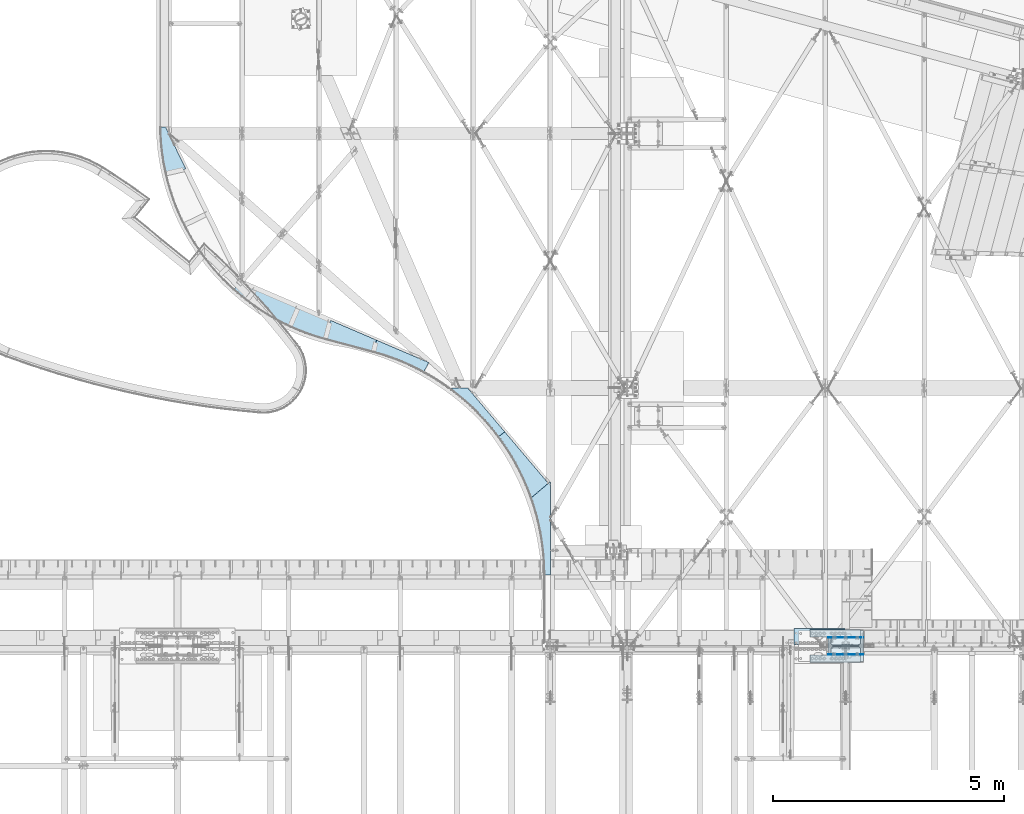
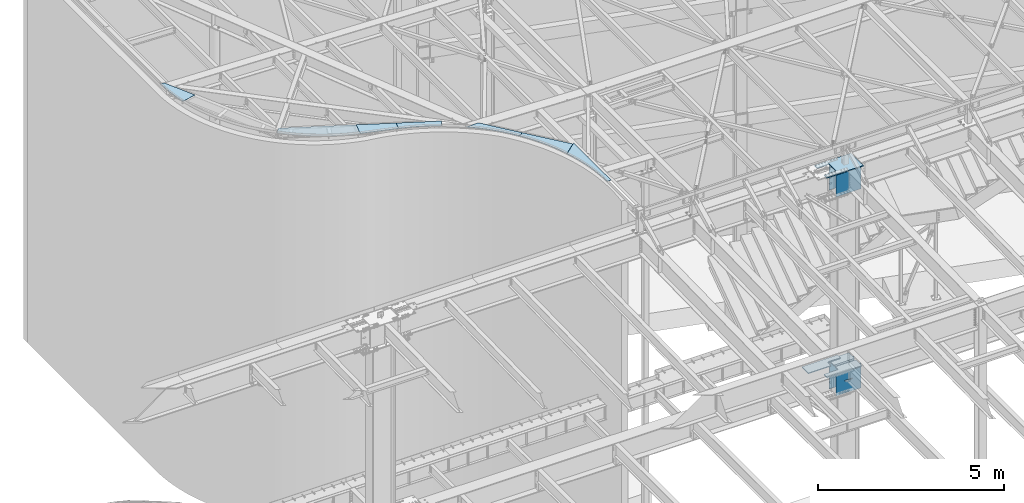
# One storey, part 1424 of 1763: 15 plates, 6 elements without a shape of their own.
"""IFC2X3 building model written with IfcOpenShell, lengths in millimetres."""

from ifc_helpers import new_model, si_unit, frame, origin_with_axes, place, context, subcontext, project, spatial, faceted_brep, material, type_object, element, aggregate, save


model = new_model("IFC2X3")

# Units and contexts
model_context = context("Model", 3, precision=1e-05, world=origin_with_axes())
body_context = subcontext(model_context, "Body", "Model", "MODEL_VIEW")
ifc_project = project(units=[si_unit("LENGTHUNIT", "METRE", prefix="MILLI"), si_unit("AREAUNIT", "SQUARE_METRE"), si_unit("VOLUMEUNIT", "CUBIC_METRE"), si_unit("MASSUNIT", "GRAM", prefix="KILO"), si_unit("TIMEUNIT", "SECOND"), si_unit("PLANEANGLEUNIT", "RADIAN"), si_unit("SOLIDANGLEUNIT", "STERADIAN"), si_unit("THERMODYNAMICTEMPERATUREUNIT", "DEGREE_CELSIUS"), si_unit("LUMINOUSINTENSITYUNIT", "LUMEN")], contexts=[model_context])

# Site, building, storey
site_placement = place(None, origin_with_axes())
site = spatial("IfcSite", under=ifc_project, at=site_placement, CompositionType="ELEMENT")
building_placement = place(site_placement, origin_with_axes())
building = spatial("IfcBuilding", under=site, at=building_placement, Name="Undefined", CompositionType="ELEMENT")
storey_placement = place(building_placement, origin_with_axes())
storey = spatial("IfcBuildingStorey", under=building, at=storey_placement, Name="Undefined", CompositionType="ELEMENT", Elevation=0.0)

# Assembly, plate
assembly_1_placement = place(storey_placement, origin_with_axes())
assembly_1 = element("IfcElementAssembly", 1, at=assembly_1_placement, inside=storey, Name="BEAM", AssemblyPlace="NOTDEFINED", PredefinedType="RIGID_FRAME")
ifc_material_1 = material(Name="STEEL/A36")
plate_type_1 = type_object("IfcPlateType", PredefinedType="NOTDEFINED")
plate_1_placement = place(assembly_1_placement, frame((-49648.670087662, 62339.0395447258, 12733.9691789539), z_axis=(-0.223550298253308, 0.974646099846385, 0.00949969499972398), x_axis=(0.974683206072181, 0.223579893016565, -0.00216315500016218)))
plate_1 = element("IfcPlate", 2, at=plate_1_placement, type_object=plate_type_1, material=ifc_material_1, Name="PLATE", context=body_context, shape_type="Brep", body=[
    faceted_brep([(1.33448866537947, -3.17499999995744, 104.323684619914), (1.34822535161948, 3.17500000004111, 104.263358693439), (0.937106392200803, 3.17499999999563, 1.45519152283669e-11), (0.92313183589431, -3.17500000000291, 0.0), (9.89252849467448, -3.17499999986649, 297.738603713762), (9.90626518091449, 3.17500000013206, 297.678277787301), (26.2313351696866, -3.17499999977372, 490.651890645284), (26.2450718559267, 3.17500000022665, 490.591564718823), (50.3244070862347, -3.17499999967367, 682.750639357633), (50.3381437724747, 3.17500000032669, 682.690313431158), (82.1326651935597, -3.17499999956999, 873.723264977889), (82.1464018797924, 3.17500000042855, 873.662939051414), (109.603907540455, -3.17499999949905, 1005.63523965912), (109.629004539267, 3.17500000050313, 1005.62946391445), (213.412231446287, -3.17499999944448, 981.745117184619), (439.812011718124, -3.17499999973006, -1.45519152283669e-11), (439.812011718132, 3.17500000026848, 1.45519152283669e-11), (213.412231446295, 3.1750000005577, 981.745117184633)], [[[0, 1, 2, 3]], [[4, 5, 1, 0]], [[6, 7, 5, 4]], [[8, 9, 7, 6]], [[10, 11, 9, 8]], [[12, 13, 11, 10]], [[14, 15, 16, 17]], [[8, 6, 4, 0, 3, 15, 14, 12, 10]], [[16, 15, 3, 2]], [[17, 16, 2, 1, 5, 7, 9, 11, 13]], [[14, 17, 13, 12]]]),
])
aggregate(assembly_1, [plate_1])

# Assembly, plates
assembly_2_placement = place(storey_placement, origin_with_axes())
assembly_2 = element("IfcElementAssembly", 3, at=assembly_2_placement, inside=storey, Name="BEAM", AssemblyPlace="NOTDEFINED", PredefinedType="RIGID_FRAME")
plate_type_2 = type_object("IfcPlateType", PredefinedType="NOTDEFINED")
plate_2_placement = place(assembly_2_placement, frame((-46201.9714651139, 58759.1172312443, 12641.5934711025), z_axis=(-0.965590600405951, 0.258452114647502, 0.0289360820068796), x_axis=(0.258673208951071, 0.965956134817291, 0.00411297699922236)))
plate_2 = element("IfcPlate", 4, at=plate_2_placement, type_object=plate_type_2, material=ifc_material_1, Name="PLATE", context=body_context, shape_type="Brep", body=[
    faceted_brep([(0.436761683944496, -3.17499999992651, 99.9227465770309), (0.410633117928228, 3.17500000007567, 99.7389239276454), (0.383936294565501, 3.17500000000291, 1.45519152283669e-11), (0.410015657325857, -3.17500000000109, -7.27595761418343e-12), (8.28393571890774, -3.17499999978463, 293.44122971109), (8.25780715289875, 3.17500000021755, 293.257407061719), (23.9137147723668, -3.17499999964639, 486.48759324156), (23.8875862063505, 3.17500000035579, 486.303770592196), (47.3007472855315, -3.17499999951542, 678.748715260874), (47.2746187195226, 3.17500000048858, 678.564892611503), (78.4070994061549, -3.17499999938445, 869.912747526017), (78.3809708401459, 3.17500000061955, 869.728924876646), (117.182316517348, -3.17499999926076, 1059.66962127761), (117.156187951339, 3.17500000074142, 1059.48579862823), (163.563505075144, -3.17499999914071, 1247.71155017251), (163.537376509143, 3.17500000086147, 1247.52772752313), (217.475434622109, -3.17499999902429, 1433.73352951439), (217.4493060561, 3.17500000097789, 1433.54970686501), (278.830659811356, -3.17499999891515, 1617.43383097253), (278.804531245347, 3.17500000108703, 1617.25000832315), (347.52966224328, -3.17499999880965, 1798.51449198617), (347.503533677263, 3.17500000119253, 1798.33066933679), (423.461011884683, -3.17499999871143, 1976.68179906098), (423.434883318681, 3.17500000129075, 1976.49797641161), (506.50154780881, -3.17499999861684, 2151.64676417335), (506.475419242801, 3.17500000138352, 2151.46294152396), (520.30531817623, 3.17500000139989, 2177.80892923436), (519.969908838983, -3.17499999860411, 2177.30402138722), (721.798583986973, -3.17499999876236, 2086.52441406271), (419.779144286287, -3.17500000018663, 6.76664058119059e-10), (419.779144286287, 3.17499999981555, 6.91215973347425e-10), (721.79858398698, 3.17500000123982, 2086.52441406274), (526.01147461254, -3.17499999859865, 2186.39868164014), (526.011474612555, 3.17500000140353, 2186.39868164016)], [[[0, 1, 2, 3]], [[4, 5, 1, 0]], [[6, 7, 5, 4]], [[8, 9, 7, 6]], [[10, 11, 9, 8]], [[12, 13, 11, 10]], [[14, 15, 13, 12]], [[16, 17, 15, 14]], [[18, 19, 17, 16]], [[20, 21, 19, 18]], [[22, 23, 21, 20]], [[24, 25, 23, 22]], [[26, 25, 24, 27]], [[28, 29, 30, 31]], [[32, 28, 31, 33]], [[32, 33, 26, 27]], [[22, 20, 18, 16, 14, 12, 10, 8, 6, 4, 0, 3, 29, 28, 32, 27, 24]], [[30, 29, 3, 2]], [[33, 31, 30, 2, 1, 5, 7, 9, 11, 13, 15, 17, 19, 21, 23, 25, 26]]]),
])
plate_type_3 = type_object("IfcPlateType", PredefinedType="NOTDEFINED")
plate_3_placement = place(assembly_2_placement, frame((-45164.36661686, 58481.1173834425, 12610.5413911031), z_axis=(-0.965492225102044, 0.25882786883883, 0.0288599650009163), x_axis=(0.259044451054952, 0.965857233204925, 0.00397208300084522)))
plate_3 = element("IfcPlate", 5, at=plate_3_placement, type_object=plate_type_3, material=ifc_material_1, Name="PLATE", context=body_context, shape_type="Brep", body=[
    faceted_brep([(1.81898940354586e-12, -3.17500000000291, 0.0), (-0.155791278855759, -3.17500000032487, 1074.64880370891), (-0.155791278848483, 3.17499999967913, 1074.6488037089), (-1.81898940354586e-12, 3.17499999997381, 0.0), (419.616851810519, -3.17500000037944, 1074.75463866899), (419.616851810533, 3.17499999962274, 1074.75463866898), (264.473388671919, -3.17500000003747, 2.03726813197136e-10), (264.473388671933, 3.17499999996289, 1.96450855582952e-10)], [[[0, 1, 2, 3]], [[1, 4, 5, 2]], [[4, 6, 7, 5]], [[6, 0, 3, 7]], [[5, 7, 3, 2]], [[6, 4, 1, 0]]]),
])
plate_type_4 = type_object("IfcPlateType", PredefinedType="NOTDEFINED")
plate_4_placement = place(assembly_2_placement, frame((-44075.7581933841, 58046.6956866533, 12576.17862546), z_axis=(-0.878456539526698, 0.476931535113362, 0.0291619439885471), x_axis=(0.477062161074467, 0.878865254137213, -0.00274946200042837)))
plate_4 = element("IfcPlate", 6, at=plate_4_placement, type_object=plate_type_4, material=ifc_material_1, Name="PLATE", context=body_context, shape_type="Brep", body=[
    faceted_brep([(-137.070634946282, -3.17500000012478, 1159.56341433973), (-137.044663511595, 3.17499999987922, 1159.34370626365), (-122.40731121448, 3.17499999988831, 1100.05283856152), (-122.424777792756, -3.17500000011569, 1100.23809639651), (-82.9073969918172, 3.17499999991742, 907.938576748842), (-82.9248635700824, -3.1750000000884, 908.12383458385), (-50.9770026533697, 3.17499999994106, 714.421619759582), (-50.9944692316494, -3.17500000006294, 714.606877594575), (-26.665362552867, 3.17499999996107, 519.800356715001), (-26.6828291311322, -3.17500000004111, 519.985614550009), (-10.0099634771759, 3.17499999998108, 324.374879496274), (-10.0274300554483, -3.17500000002474, 324.560137331282), (-1.03648684448854, 3.17499999999382, 128.44652002459), (-1.05395342275369, -3.17500000000837, 128.631777859599), (1.81898940354586e-12, -3.17500000000291, 0.0), (-1.81898940354586e-12, 3.17499999997381, 0.0), (-137.652465818221, -3.17500000012478, 1164.48547363198), (119.54241943646, -3.17500000001382, 1226.19409179671), (119.542419436439, 3.17499999998836, 1226.19409179673), (-137.652465818235, 3.17499999987922, 1164.48547363198), (232.689422608019, -3.17499999990105, 1.04773789644241e-09), (232.689422608, 3.17500000010295, 1.06228981167078e-09)], [[[0, 1, 2, 3]], [[3, 2, 4, 5]], [[5, 4, 6, 7]], [[7, 6, 8, 9]], [[9, 8, 10, 11]], [[11, 10, 12, 13]], [[14, 13, 12, 15]], [[16, 17, 18, 19]], [[17, 20, 21, 18]], [[21, 20, 14, 15]], [[10, 8, 6, 4, 2, 1, 19, 18, 21, 15, 12]], [[16, 19, 1, 0]], [[20, 17, 16, 0, 3, 5, 7, 9, 11, 13, 14]]]),
])
aggregate(assembly_2, [plate_2, plate_3, plate_4])

assembly_3_placement = place(storey_placement, origin_with_axes())
assembly_3 = element("IfcElementAssembly", 7, at=assembly_3_placement, inside=storey, Name="BEAM", AssemblyPlace="NOTDEFINED", PredefinedType="RIGID_FRAME")
plate_type_5 = type_object("IfcPlateType", PredefinedType="NOTDEFINED")
plate_5_placement = place(assembly_3_placement, frame((-42458.4282072323, 56648.6465872894, 12528.3525811521), z_axis=(-0.598719051084489, 0.800637167134818, 0.0227073660036058), x_axis=(0.800846988935664, 0.5988689669519, 0.000246443999979276)))
plate_5 = element("IfcPlate", 8, at=plate_5_placement, type_object=plate_type_5, material=ifc_material_1, Name="PLATE", context=body_context, shape_type="Brep", body=[
    faceted_brep([(-225.063934327466, -3.17500000101791, 1483.56762695631), (-225.063934327455, 3.17499999898791, 1483.5676269563), (-222.826591483198, 3.17499999899155, 1476.91430981157), (-222.825026160161, -3.17500000101427, 1477.05853877887), (-168.505988429088, 3.17499999910797, 1288.49196273007), (-168.504423106043, -3.17500000089422, 1288.63619169737), (-121.622795991748, 3.17499999923166, 1098.08167421172), (-121.621230668696, -3.17500000077234, 1098.22590317902), (-82.2493046557632, 3.17499999935899, 905.977043120205), (-82.2477393327043, -3.17500000064319, 906.121272087519), (-50.4462254909028, 3.17499999948996, 712.474280872673), (-50.4446601678512, -3.17500000051223, 712.618509839973), (-26.2625965401414, 3.17499999962638, 517.871754703126), (-26.2610312170825, -3.17500000037762, 518.015983670441), (-9.73570720642432, 3.17499999976462, 322.46952760189), (-9.73414188337999, -3.17500000023938, 322.613756569175), (-0.891040755230676, 3.1749999999065, 126.568895640041), (-0.889475432186345, -3.17500000009386, 126.71312460734), (1.81898940354586e-12, -3.17500000000291, 0.0), (-1.81898940354586e-12, 3.17499999997381, 0.0), (95.9917373657721, -3.17500000096516, 1243.06909179941), (170.599929810258, -3.17500000007021, -5.5297277867794e-10), (170.599929810269, 3.17499999993379, -5.5297277867794e-10), (95.9917373657836, 3.17499999903703, 1243.06909179941)], [[[0, 1, 2, 3]], [[3, 2, 4, 5]], [[5, 4, 6, 7]], [[7, 6, 8, 9]], [[9, 8, 10, 11]], [[11, 10, 12, 13]], [[13, 12, 14, 15]], [[15, 14, 16, 17]], [[18, 17, 16, 19]], [[20, 21, 22, 23]], [[22, 21, 18, 19]], [[14, 12, 10, 8, 6, 4, 2, 1, 23, 22, 19, 16]], [[20, 23, 1, 0]], [[21, 20, 0, 3, 5, 7, 9, 11, 13, 15, 17, 18]]]),
])
plate_type_6 = type_object("IfcPlateType", PredefinedType="NOTDEFINED")
plate_6_placement = place(assembly_3_placement, frame((-41751.4899670455, 55326.9585626116, 12501.5959184609), z_axis=(-0.64801181653115, 0.761411246764189, 0.0182646909911691), x_axis=(0.761538281540342, 0.64811993160879, 0.0)))
plate_6 = element("IfcPlate", 9, at=plate_6_placement, type_object=plate_type_6, material=ifc_material_1, Name="PLATE", context=body_context, shape_type="Brep", body=[
    faceted_brep([(23.2689841487495, -3.17499999996653, 58.605816979165), (23.2689841487459, 3.17500000002838, 58.489816841), (0.497949358149981, 3.17499999999745, -1.45519152283669e-11), (0.452788622050775, -3.17499999999745, -1.45519152283669e-11), (87.1774335224782, -3.17499999987012, 243.977579717859), (87.1774335224745, 3.17500000012296, 243.861579579694), (143.760164557034, -3.17499999977554, 431.715880103613), (143.760164557027, 3.17500000021937, 431.599879965448), (192.929930782362, -3.17499999967549, 621.531239284828), (192.929930782351, 3.1750000003176, 621.415239146678), (234.610915982832, -3.17499999957727, 813.130975735723), (234.610915982825, 3.17500000041764, 813.014975597558), (268.738851100354, -3.17499999948086, 1006.21965655011), (268.73885110035, 3.17500000051405, 1006.10365641193), (295.261113332637, -3.174999999379, 1200.4995529775), (295.261113332634, 3.17500000061591, 1200.38355283934), (314.136807273686, -3.17499999927895, 1395.6710994993), (314.136807273679, 3.17500000071595, 1395.55509936114), (318.257141109842, -3.17499999924257, 1464.95507812782), (318.257141109831, 3.17500000075052, 1464.95507812782), (488.518341061534, -3.17499999924621, 1454.20776367481), (484.193817140082, -3.17499999998836, 6.54836185276508e-10), (484.193817140074, 3.17500000000473, 6.54836185276508e-10), (488.51834106153, 3.17500000074688, 1454.20776367481)], [[[0, 1, 2, 3]], [[4, 5, 1, 0]], [[6, 7, 5, 4]], [[8, 9, 7, 6]], [[10, 11, 9, 8]], [[12, 13, 11, 10]], [[14, 15, 13, 12]], [[16, 17, 15, 14]], [[18, 19, 17, 16]], [[20, 21, 22, 23]], [[14, 12, 10, 8, 6, 4, 0, 3, 21, 20, 18, 16]], [[22, 21, 3, 2]], [[23, 22, 2, 1, 5, 7, 9, 11, 13, 15, 17, 19]], [[20, 23, 19, 18]]]),
])
aggregate(assembly_3, [plate_5, plate_6])

# Assembly, plate
assembly_4_placement = place(storey_placement, origin_with_axes())
assembly_4 = element("IfcElementAssembly", 10, at=assembly_4_placement, inside=storey, Name="BEAM", AssemblyPlace="NOTDEFINED", PredefinedType="RIGID_FRAME")
plate_type_7 = type_object("IfcPlateType", PredefinedType="NOTDEFINED")
plate_7_placement = place(assembly_4_placement, frame((-41463.338, 53658.235, 12498.189063), z_axis=(0.000174910999972781, 0.999999984703071, 0.0), x_axis=(0.999999984703071, -0.000174910999972303, 0.0)))
plate_7 = element("IfcPlate", 11, at=plate_7_placement, type_object=plate_type_7, material=ifc_material_1, Name="PLATE", context=body_context, shape_type="Brep", body=[
    faceted_brep([(-287.005828855668, -3.17499999999927, 1666.03820801304), (-287.005828855668, 3.17499999999927, 1666.03820801304), (-244.409507782955, 3.17499999999927, 1543.11187569349), (-244.409507782955, -3.17499999999927, 1543.11187569349), (-187.466446308768, 3.17499999999927, 1355.51388872293), (-187.466446308768, -3.17499999999927, 1355.51388872293), (-137.932348276554, 3.17499999999927, 1165.82495889941), (-137.932348276554, -3.17499999999927, 1165.82495889941), (-95.8835916751923, 3.17499999999927, 974.337572803772), (-95.8835916751923, -3.17499999999927, 974.337572803772), (-61.3850126395846, 3.17499999999927, 781.346990106111), (-61.3850126395846, -3.17499999999927, 781.346990106111), (-34.4898054781079, 3.17499999999927, 587.150788296698), (-34.4898054781079, -3.17499999999927, 587.150788296698), (-15.2394406507956, 3.17499999999927, 392.04840384311), (-15.2394406507956, -3.17499999999927, 392.04840384311), (-3.66360082491883, 3.17499999999927, 196.340670480866), (-3.66360082491883, -3.17499999999927, 196.340670480866), (0.219864893537306, -3.17499999999927, 0.329355349640537), (0.219864893537306, 3.17499999999927, 0.329355349640537), (-1.81898940354586e-12, 3.17499999997381, 0.0), (1.81898940354586e-12, -3.17500000000291, 0.0), (124.447143558158, -3.17499999999927, 2016.14282227121), (124.799781799316, -3.17499999999927, 0.0), (124.799781799316, 3.17499999999927, 0.0), (124.447143558158, 3.17499999999927, 2016.14282227121)], [[[0, 1, 2, 3]], [[3, 2, 4, 5]], [[5, 4, 6, 7]], [[7, 6, 8, 9]], [[9, 8, 10, 11]], [[11, 10, 12, 13]], [[13, 12, 14, 15]], [[15, 14, 16, 17]], [[18, 19, 20, 21]], [[17, 16, 19, 18]], [[22, 23, 24, 25]], [[23, 21, 20, 24]], [[14, 12, 10, 8, 6, 4, 2, 1, 25, 24, 20, 19, 16]], [[22, 25, 1, 0]], [[23, 22, 0, 3, 5, 7, 9, 11, 13, 15, 17, 18, 21]]]),
])
aggregate(assembly_4, [plate_7])

# Assembly, plates
assembly_5_placement = place(storey_placement, origin_with_axes())
assembly_5 = element("IfcElementAssembly", 12, at=assembly_5_placement, inside=storey, Name="COLUMN", AssemblyPlace="NOTDEFINED", PredefinedType="RIGID_FRAME")
ifc_material_2 = material(Name="STEEL/A572-50")
plate_type_8 = type_object("IfcPlateType", PredefinedType="NOTDEFINED")
plate_8_placement = place(assembly_5_placement, frame((-34627.5747744613, 52473.2250062685, 5180.0125), z_axis=(-1.0, 0.0, 0.0), x_axis=(0.0, -1.0, 0.0)))
plate_8 = element("IfcPlate", 13, at=plate_8_placement, type_object=plate_type_8, material=ifc_material_2, Name="PLATE", context=body_context, shape_type="Brep", body=[
    faceted_brep([(0.0, -14.2875000000058, 0.0), (0.0, 14.2875000000058, 0.0), (304.800007959304, 14.2875000000004, 0.0), (304.800007959304, -14.2875000000004, 0.0), (6.26846303930506e-06, -14.2875000000004, 1092.20007324219), (6.26846303930506e-06, 14.2875000000004, 1092.20007324219), (158.750006268478, -14.2875000000004, 1092.20007324219), (158.750006268478, 14.2875000000004, 1092.20007324219), (158.750064118947, -14.2875000000004, 657.225009071313), (158.750064118947, 14.2875000000004, 657.225009071313), (159.716794486558, -14.2875000000004, 652.364930167954), (159.716794486558, 14.2875000000004, 652.364930167954), (162.469808392249, -14.2875000000004, 648.24475432394), (162.469808392249, 14.2875000000004, 648.24475432394), (166.58998451232, -14.2875000000004, 645.491740831385), (166.58998451232, 14.2875000000004, 645.491740831385), (171.450063512617, -14.2875000000004, 644.525010951111), (171.450063512617, 14.2875000000004, 644.525010951111), (304.800004047371, -14.2875000000004, 644.525006587348), (304.800004047371, 14.2875000000004, 644.525006587348), (342.900001264425, -14.2875000000004, 606.425006866433), (314.320970960893, 14.2875000000004, 635.004039049672), (314.320965331543, 14.2875000000004, 9.5209573722459), (342.900006433403, -14.2875000000004, 38.0999984741284)], [[[0, 1, 2, 3]], [[0, 4, 5, 1]], [[5, 4, 6, 7]], [[6, 8, 9, 7]], [[10, 11, 9, 8]], [[12, 13, 11, 10]], [[14, 15, 13, 12]], [[16, 17, 15, 14]], [[17, 16, 18, 19]], [[19, 18, 20, 21]], [[2, 1, 5, 7, 9, 11, 13, 15, 17, 19, 21, 22]], [[3, 2, 22, 23]], [[18, 16, 14, 12, 10, 8, 6, 4, 0, 3, 23, 20]], [[22, 21, 20, 23]]]),
])
plate_9_placement = place(assembly_5_placement, frame((-34627.5747744613, 51768.3750062685, 5180.0125), z_axis=(-1.0, 0.0, 0.0), x_axis=(0.0, 1.0, 0.0)))
plate_9 = element("IfcPlate", 14, at=plate_9_placement, type_object=plate_type_8, material=ifc_material_2, Name="PLATE", context=body_context, shape_type="Brep", body=[
    faceted_brep([(0.0, -14.2875000000058, 0.0), (0.0, 14.2875000000058, 0.0), (304.800007959304, 14.2875000000004, 0.0), (304.800007959304, -14.2875000000004, 0.0), (6.26846303930506e-06, -14.2875000000004, 1092.20007324219), (6.26846303930506e-06, 14.2875000000004, 1092.20007324219), (158.750006268478, -14.2875000000004, 1092.20007324219), (158.750006268478, 14.2875000000004, 1092.20007324219), (158.750064118947, -14.2875000000004, 657.225009071313), (158.750064118947, 14.2875000000004, 657.225009071313), (159.716794486558, -14.2875000000004, 652.364930167954), (159.716794486558, 14.2875000000004, 652.364930167954), (162.469808392249, -14.2875000000004, 648.24475432394), (162.469808392249, 14.2875000000004, 648.24475432394), (166.58998451232, -14.2875000000004, 645.491740831385), (166.58998451232, 14.2875000000004, 645.491740831385), (171.450063512617, -14.2875000000004, 644.525010951111), (171.450063512617, 14.2875000000004, 644.525010951111), (304.800004047371, -14.2875000000004, 644.525006587348), (304.800004047371, 14.2875000000004, 644.525006587348), (342.899993896484, 14.2875000000004, 606.425006866433), (342.899993896484, 14.2875000000004, 38.0999984741284), (314.324994082315, -14.2875000000004, 9.52499865994469), (314.324988453038, -14.2875000000004, 635.000009020332)], [[[0, 1, 2, 3]], [[0, 4, 5, 1]], [[5, 4, 6, 7]], [[6, 8, 9, 7]], [[10, 11, 9, 8]], [[12, 13, 11, 10]], [[14, 15, 13, 12]], [[16, 17, 15, 14]], [[17, 16, 18, 19]], [[2, 1, 5, 7, 9, 11, 13, 15, 17, 19, 20, 21]], [[3, 2, 21, 22]], [[18, 16, 14, 12, 10, 8, 6, 4, 0, 3, 22, 23]], [[19, 18, 23, 20]], [[22, 21, 20, 23]]]),
])
plate_type_9 = type_object("IfcPlateType", PredefinedType="NOTDEFINED")
plate_10_placement = place(assembly_5_placement, frame((-35710.2497736983, 52454.1750002128, 11733.2124917654), z_axis=(1.0, 0.0, 0.0), x_axis=(0.0, -1.0, 0.0)))
plate_10 = element("IfcPlate", 15, at=plate_10_placement, type_object=plate_type_9, material=ifc_material_2, Name="PLATE", context=body_context, shape_type="Brep", body=[
    faceted_brep([(139.700000000004, -14.2875000000004, 0.0), (139.700000000004, 14.2875000000004, 0.0), (139.700000352379, 14.2875000000004, 352.425012588552), (139.700000352379, -14.2875000000004, 352.425012588552), (141.63346020726, 14.2875000000004, 362.145171622687), (141.63346020726, -14.2875000000004, 362.145171622687), (147.139488016437, 14.2875000000004, 370.38552455348), (147.139488016437, -14.2875000000004, 370.38552455348), (155.379840958223, 14.2875000000004, 375.891552346206), (155.379840958223, -14.2875000000004, 375.891552346206), (165.099999996222, 14.2875000000004, 377.825012181682), (165.099999996222, -14.2875000000004, 377.825012181682), (501.650006861608, 14.2875000000004, 377.825011846209), (501.650006861608, -14.2875000000004, 377.825011846209), (511.370165895773, 14.2875000000004, 375.891551991343), (511.370165895773, -14.2875000000004, 375.891551991343), (519.610518826594, 14.2875000000004, 370.385524182173), (519.610518826594, -14.2875000000004, 370.385524182173), (525.116546619334, 14.2875000000004, 362.14517124038), (525.116546619334, -14.2875000000004, 362.14517124038), (527.050006454818, -14.2875000000004, 352.425012202359), (527.050006454818, 14.2875000000004, 352.425012202359), (527.05000610352, 14.2875000000004, -1.45519152283669e-11), (527.05000610352, -14.2875000000004, -1.45519152283669e-11), (0.0, -14.2875000000058, 0.0), (0.0, -14.2875000000004, 1143.0), (0.0, 14.2875000000004, 1143.0), (0.0, 14.2875000000058, 0.0), (666.75, -14.2875000000004, 1143.0), (666.75, 14.2875000000004, 1143.0), (666.75, -14.2875000000004, -1.45519152283669e-11), (666.75, 14.2875000000004, -1.45519152283669e-11)], [[[0, 1, 2, 3]], [[3, 2, 4, 5]], [[5, 4, 6, 7]], [[7, 6, 8, 9]], [[9, 8, 10, 11]], [[11, 10, 12, 13]], [[13, 12, 14, 15]], [[15, 14, 16, 17]], [[17, 16, 18, 19]], [[20, 21, 22, 23]], [[19, 18, 21, 20]], [[24, 25, 26, 27]], [[25, 28, 29, 26]], [[28, 30, 31, 29]], [[31, 30, 23, 22]], [[16, 14, 12, 10, 8, 6, 4, 2, 1, 27, 26, 29, 31, 22, 21, 18]], [[24, 27, 1, 0]], [[30, 28, 25, 24, 0, 3, 5, 7, 9, 11, 13, 15, 17, 19, 20, 23]]]),
])
plate_type_10 = type_object("IfcPlateType", PredefinedType="NOTDEFINED")
plate_11_placement = place(assembly_5_placement, frame((-35332.4247615072, 51935.0625, 11718.9249917654), z_axis=(0.0, 0.0, -1.0), x_axis=(1.0, 0.0, 0.0)))
plate_11 = element("IfcPlate", 16, at=plate_11_placement, type_object=plate_type_10, material=ifc_material_2, Name="COVER PLATE", context=body_context, shape_type="Brep", body=[
    faceted_brep([(-7.27595761418343e-12, -7.9375, 0.0), (-1.2191194400657e-05, -7.9375, 825.5), (-1.2191194400657e-05, 7.9375, 825.5), (-7.27595761418343e-12, 7.9375, 0.0), (765.174987792969, -7.9375, 825.5), (765.174987792969, 7.9375, 825.5), (765.174987792969, -7.9375, 0.0), (765.174987792969, 7.9375, 0.0)], [[[0, 1, 2, 3]], [[1, 4, 5, 2]], [[4, 6, 7, 5]], [[6, 0, 3, 7]], [[5, 7, 3, 2]], [[6, 4, 1, 0]]]),
])
plate_12_placement = place(assembly_5_placement, frame((-35332.4247615072, 52306.5375, 11718.9249917654), z_axis=(0.0, 0.0, -1.0), x_axis=(1.0, 0.0, 0.0)))
plate_12 = element("IfcPlate", 17, at=plate_12_placement, type_object=plate_type_10, material=ifc_material_2, Name="COVER PLATE", context=body_context, shape_type="Brep", body=[
    faceted_brep([(-7.27595761418343e-12, -7.9375, 0.0), (-1.2191194400657e-05, -7.9375, 825.5), (-1.2191194400657e-05, 7.9375, 825.5), (-7.27595761418343e-12, 7.9375, 0.0), (765.174987792969, -7.9375, 825.5), (765.174987792969, 7.9375, 825.5), (765.174987792969, -7.9375, 0.0), (765.174987792969, 7.9375, 0.0)], [[[0, 1, 2, 3]], [[1, 4, 5, 2]], [[4, 6, 7, 5]], [[6, 0, 3, 7]], [[5, 7, 3, 2]], [[6, 4, 1, 0]]]),
])
plate_13_placement = place(assembly_5_placement, frame((-35332.4247736984, 51935.0625, 5165.725), z_axis=(0.0, 0.0, -1.0), x_axis=(1.0, 0.0, 0.0)))
plate_13 = element("IfcPlate", 18, at=plate_13_placement, type_object=plate_type_10, material=ifc_material_2, Name="COVER PLATE", context=body_context, shape_type="Brep", body=[
    faceted_brep([(19.0499815529183, 7.93750682487007, 15.8750000047403), (19.0499815529183, -7.9375, 0.0), (19.0499815529183, 7.9375, 0.0), (79.37498155293, 7.93750682487007, 15.8750000047403), (79.37498155293, -7.9375, 0.0), (-7.27595761418343e-12, -7.9375, 0.0), (-7.27595761418343e-12, 7.9375, 0.0), (0.0, -7.9375, 822.324951171875), (0.0, 7.9375, 822.324951171875), (765.174987792969, -7.9375, 822.324951171875), (765.174987792969, 7.9375, 822.324951171875), (765.174987792969, -7.9375, 0.0), (765.174987792969, 7.9375, 0.0), (685.799981552918, -7.9375, 0.0), (685.799981552918, 7.9375, 0.0), (685.799981552918, 7.93750682487007, 15.8750000047403), (504.745217649033, 7.9375, 423.782724431523), (501.140063123385, 7.9375, 426.191611671965), (496.887493408227, 7.9375, 427.037500381452), (268.287496841454, 7.9375, 427.037500381452), (264.034927126311, 7.9375, 426.191611671965), (260.429772600648, 7.9375, 423.782724431523), (258.020885360209, 7.9375, 420.177569905865), (257.17499665072, 7.9375, 415.925000190718), (258.020885360209, 7.9375, 411.672430475577), (260.429772600648, 7.9375, 408.06727594992), (264.034927126311, 7.9375, 405.658388709478), (268.287496841454, 7.9375, 404.812499999991), (496.887493408227, 7.9375, 404.812499999983), (501.140063123385, 7.9375, 405.65838870947), (504.745217649033, 7.9375, 408.067275949912), (507.154104889487, 7.9375, 411.67243047557), (507.999993598962, 7.9375, 415.925000190718), (507.154104889487, 7.9375, 420.177569905865), (507.154104857837, -7.9375, 420.177569905865), (507.999993567311, -7.9375, 415.925000190718), (504.745217617383, -7.9375, 423.782724431523), (501.140063091734, -7.9375, 426.191611671965), (496.887493376576, -7.9375, 427.037500381452), (268.287496809804, -7.9375, 427.037500381452), (264.034927094661, -7.9375, 426.191611671965), (260.429772569012, -7.9375, 423.782724431523), (258.020885328559, -7.9375, 420.177569905865), (257.174996619069, -7.9375, 415.925000190718), (258.020885328559, -7.9375, 411.672430475577), (260.429772569012, -7.9375, 408.06727594992), (264.034927094661, -7.9375, 405.658388709478), (268.287496809804, -7.9375, 404.812499999991), (496.887493376576, -7.9375, 404.812499999983), (501.140063091734, -7.9375, 405.65838870947), (504.745217617383, -7.9375, 408.067275949912), (507.154104857837, -7.9375, 411.67243047557)], [[[0, 1, 2]], [[3, 4, 1, 0]], [[5, 6, 2, 1]], [[5, 7, 8, 6]], [[7, 9, 10, 8]], [[9, 11, 12, 10]], [[12, 11, 13, 14]], [[14, 13, 15]], [[2, 6, 8, 10, 12, 14, 15, 3, 0], [16, 17, 18, 19, 20, 21, 22, 23, 24, 25, 26, 27, 28, 29, 30, 31, 32, 33]], [[34, 33, 32, 35]], [[36, 16, 33, 34]], [[37, 17, 16, 36]], [[38, 18, 17, 37]], [[39, 19, 18, 38]], [[40, 20, 19, 39]], [[41, 21, 20, 40]], [[42, 22, 21, 41]], [[43, 23, 22, 42]], [[44, 24, 23, 43]], [[45, 25, 24, 44]], [[46, 26, 25, 45]], [[47, 27, 26, 46]], [[48, 28, 27, 47]], [[49, 29, 28, 48]], [[50, 30, 29, 49]], [[51, 31, 30, 50]], [[35, 32, 31, 51]], [[13, 11, 9, 7, 5, 1, 4], [50, 49, 48, 47, 46, 45, 44, 43, 42, 41, 40, 39, 38, 37, 36, 34, 35, 51]], [[15, 13, 4, 3]]]),
])
plate_14_placement = place(assembly_5_placement, frame((-35332.4247736984, 52306.5375, 5165.725), z_axis=(0.0, 0.0, -1.0), x_axis=(1.0, 0.0, 0.0)))
plate_14 = element("IfcPlate", 19, at=plate_14_placement, type_object=plate_type_10, material=ifc_material_2, Name="COVER PLATE", context=body_context, shape_type="Brep", body=[
    faceted_brep([(19.0499815529183, -7.9375, 0.0), (19.0499815529183, 7.9375, 0.0), (19.0499815529183, -7.9374931751081, 15.8750000047348), (79.37498155293, -7.9374931751081, 15.8750000047348), (79.37498155293, 7.9375, 0.0), (-7.27595761418343e-12, -7.9375, 0.0), (-7.27595761418343e-12, 7.9375, 0.0), (0.0, -7.9375, 822.324951171875), (0.0, 7.9375, 822.324951171875), (765.174987792969, -7.9375, 822.324951171875), (765.174987792969, 7.9375, 822.324951171875), (765.174987792969, -7.9375, 0.0), (765.174987792969, 7.9375, 0.0), (685.799981552918, -7.9375, 0.0), (685.799981552918, 7.9375, 0.0), (685.799981552918, -7.9374931751081, 15.8750000047348), (504.745217649033, 7.9375, 423.782724431523), (501.140063123385, 7.9375, 426.191611671965), (496.887493408227, 7.9375, 427.037500381452), (268.287496841454, 7.9375, 427.037500381452), (264.034927126311, 7.9375, 426.191611671965), (260.429772600648, 7.9375, 423.782724431523), (258.020885360209, 7.9375, 420.177569905865), (257.17499665072, 7.9375, 415.925000190718), (258.020885360209, 7.9375, 411.672430475577), (260.429772600648, 7.9375, 408.06727594992), (264.034927126311, 7.9375, 405.658388709478), (268.287496841454, 7.9375, 404.812499999991), (496.887493408227, 7.9375, 404.812499999983), (501.140063123385, 7.9375, 405.65838870947), (504.745217649033, 7.9375, 408.067275949912), (507.154104889487, 7.9375, 411.67243047557), (507.999993598962, 7.9375, 415.925000190718), (507.154104889487, 7.9375, 420.177569905865), (507.154104857837, -7.9375, 420.177569905865), (507.999993567311, -7.9375, 415.925000190718), (504.745217617383, -7.9375, 423.782724431523), (501.140063091734, -7.9375, 426.191611671965), (496.887493376576, -7.9375, 427.037500381452), (268.287496809804, -7.9375, 427.037500381452), (264.034927094661, -7.9375, 426.191611671965), (260.429772569012, -7.9375, 423.782724431523), (258.020885328559, -7.9375, 420.177569905865), (257.174996619069, -7.9375, 415.925000190718), (258.020885328559, -7.9375, 411.672430475577), (260.429772569012, -7.9375, 408.06727594992), (264.034927094661, -7.9375, 405.658388709478), (268.287496809804, -7.9375, 404.812499999991), (496.887493376576, -7.9375, 404.812499999983), (501.140063091734, -7.9375, 405.65838870947), (504.745217617383, -7.9375, 408.067275949912), (507.154104857837, -7.9375, 411.67243047557)], [[[0, 1, 2]], [[3, 2, 1, 4]], [[5, 6, 1, 0]], [[5, 7, 8, 6]], [[7, 9, 10, 8]], [[9, 11, 12, 10]], [[12, 11, 13, 14]], [[15, 14, 13]], [[3, 4, 14, 15]], [[6, 8, 10, 12, 14, 4, 1], [16, 17, 18, 19, 20, 21, 22, 23, 24, 25, 26, 27, 28, 29, 30, 31, 32, 33]], [[34, 33, 32, 35]], [[36, 16, 33, 34]], [[37, 17, 16, 36]], [[38, 18, 17, 37]], [[39, 19, 18, 38]], [[40, 20, 19, 39]], [[41, 21, 20, 40]], [[42, 22, 21, 41]], [[43, 23, 22, 42]], [[44, 24, 23, 43]], [[45, 25, 24, 44]], [[46, 26, 25, 45]], [[47, 27, 26, 46]], [[48, 28, 27, 47]], [[49, 29, 28, 48]], [[50, 30, 29, 49]], [[51, 31, 30, 50]], [[35, 32, 31, 51]], [[15, 13, 11, 9, 7, 5, 0, 2, 3], [50, 49, 48, 47, 46, 45, 44, 43, 42, 41, 40, 39, 38, 37, 36, 34, 35, 51]]]),
])
aggregate(assembly_5, [plate_8, plate_9, plate_10, plate_11, plate_12, plate_13, plate_14])

# Assembly, plate
assembly_6_placement = place(storey_placement, origin_with_axes())
assembly_6 = element("IfcElementAssembly", 20, at=assembly_6_placement, inside=storey, Name="TOP PLATE", AssemblyPlace="NOTDEFINED", PredefinedType="RIGID_FRAME")
plate_type_11 = type_object("IfcPlateType", PredefinedType="NOTDEFINED")
plate_15_placement = place(assembly_6_placement, frame((-36072.1997736984, 52149.375, 5208.5875), z_axis=(0.0, 1.0, 0.0), x_axis=(1.0, 0.0, 0.0)))
plate_15 = element("IfcPlate", 21, at=plate_15_placement, type_object=plate_type_11, material=ifc_material_2, Name="TOP PLATE", context=body_context, shape_type="Brep", body=[
    faceted_brep([(0.0, -14.2875000000058, 0.0), (0.0, -14.2875000000004, 346.075012207031), (0.0, 14.2875000000004, 346.075012207031), (0.0, 14.2875000000058, 0.0), (1111.25, -14.2875000000004, 346.075012207031), (1111.25, 14.2875000000004, 346.075012207031), (1111.25, -14.2875000000004, 193.675003051758), (1111.25, 14.2875000000004, 193.675003051758), (749.299987792969, -14.2875000000004, 193.675003051758), (749.299987792969, 14.2875000000004, 193.675003051758), (731.074689326575, -14.2875000000004, 190.049765787611), (731.074689326575, 14.2875000000004, 190.049765787611), (715.624027338956, -14.2875000000004, 179.725963505771), (715.624027338956, 14.2875000000004, 179.725963505771), (705.300225057115, -14.2875000000004, 164.275301518144), (705.300225057115, 14.2875000000004, 164.275301518144), (701.674987792969, -14.2875000000004, 146.050003051758), (701.674987792969, 14.2875000000004, 146.050003051758), (701.674987792969, -14.2875000000004, 0.0), (701.674987792969, 14.2875000000004, 0.0)], [[[0, 1, 2, 3]], [[1, 4, 5, 2]], [[4, 6, 7, 5]], [[6, 8, 9, 7]], [[8, 10, 11, 9]], [[10, 12, 13, 11]], [[12, 14, 15, 13]], [[14, 16, 17, 15]], [[16, 18, 19, 17]], [[18, 0, 3, 19]], [[5, 7, 9, 11, 13, 15, 17, 19, 3, 2]], [[18, 16, 14, 12, 10, 8, 6, 4, 1, 0]]]),
])
aggregate(assembly_6, [plate_15])

save(model, "model.ifc")
